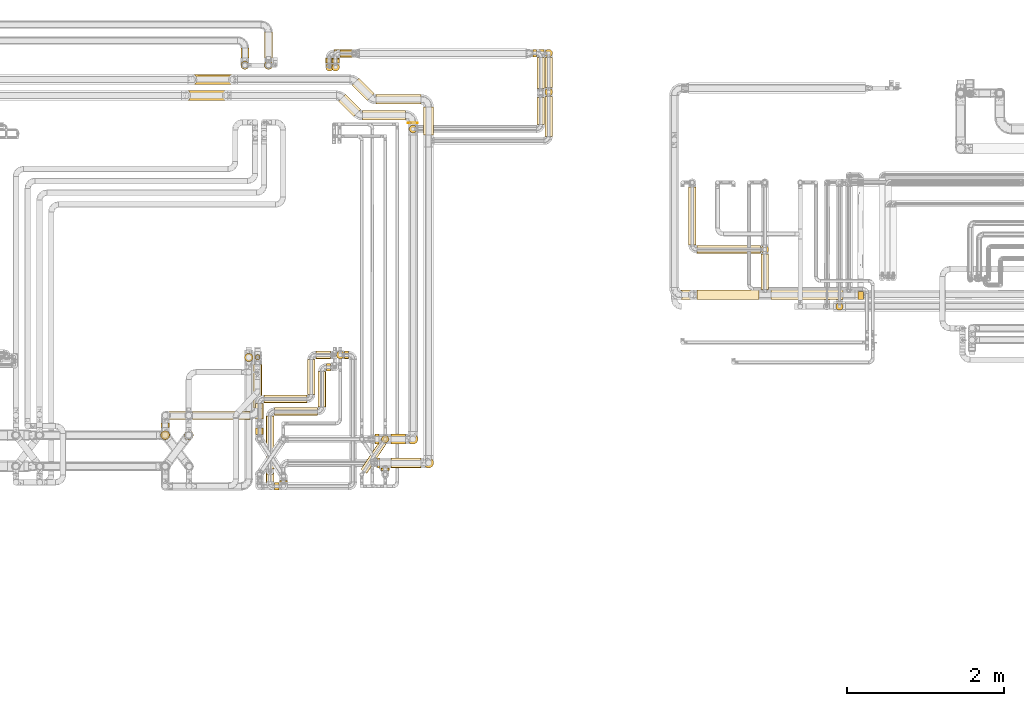
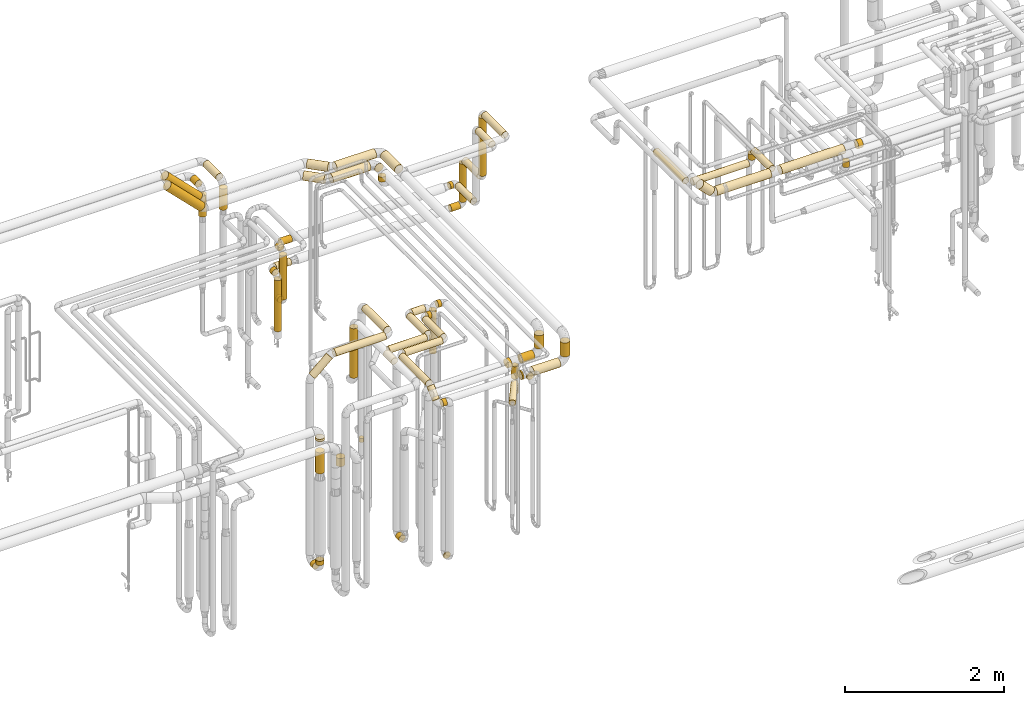
# One storey, part 16 of 824: 71 coverings.
"""IFC2X3 building model written with IfcOpenShell, lengths in millimetres."""

from ifc_helpers import new_model, entity, si_unit, converted_unit, derived_unit, direction, frame, frame_2d, origin, origin_2d_with_axis, place, context, subcontext, project, spatial, polyline, circle_curve, parameter, trimmed, segment, composite_curve, circle, outline, extrude, element, save


model = new_model("IFC2X3")

# Units and contexts
model_context = context("Model", 3, precision=0.01, world=origin(), true_north=direction((6.12303176911189e-17, 1.0)))
body_context = subcontext(model_context, "Body", "Model", "MODEL_VIEW")
ifc_project = project(units=[si_unit("LENGTHUNIT", "METRE", prefix="MILLI"), si_unit("AREAUNIT", "SQUARE_METRE"), si_unit("VOLUMEUNIT", "CUBIC_METRE"), converted_unit("PLANEANGLEUNIT", "DEGREE", entity("IfcRatioMeasure", 0.0174532925199433), si_unit("PLANEANGLEUNIT", "RADIAN"), dimensions=[0, 0, 0, 0, 0, 0, 0]), si_unit("MASSUNIT", "GRAM", prefix="KILO"), derived_unit("MASSDENSITYUNIT", [(si_unit("MASSUNIT", "GRAM", prefix="KILO"), 1), (si_unit("LENGTHUNIT", "METRE"), -3)]), derived_unit("MOMENTOFINERTIAUNIT", [(si_unit("LENGTHUNIT", "METRE"), 4)]), si_unit("TIMEUNIT", "SECOND"), si_unit("FREQUENCYUNIT", "HERTZ"), si_unit("THERMODYNAMICTEMPERATUREUNIT", "DEGREE_CELSIUS"), derived_unit("THERMALTRANSMITTANCEUNIT", [(si_unit("MASSUNIT", "GRAM", prefix="KILO"), 1), (si_unit("THERMODYNAMICTEMPERATUREUNIT", "KELVIN"), -1), (si_unit("TIMEUNIT", "SECOND"), -3)]), derived_unit("VOLUMETRICFLOWRATEUNIT", [(si_unit("LENGTHUNIT", "METRE"), 3), (si_unit("TIMEUNIT", "SECOND"), -1)]), derived_unit("MASSFLOWRATEUNIT", [(si_unit("MASSUNIT", "GRAM", prefix="KILO"), 1), (si_unit("TIMEUNIT", "SECOND"), -1)]), derived_unit("ROTATIONALFREQUENCYUNIT", [(si_unit("TIMEUNIT", "SECOND"), -1)]), si_unit("ELECTRICCURRENTUNIT", "AMPERE"), si_unit("ELECTRICVOLTAGEUNIT", "VOLT"), si_unit("POWERUNIT", "WATT"), si_unit("FORCEUNIT", "NEWTON", prefix="KILO"), si_unit("ILLUMINANCEUNIT", "LUX"), si_unit("LUMINOUSFLUXUNIT", "LUMEN"), si_unit("LUMINOUSINTENSITYUNIT", "CANDELA"), derived_unit("USERDEFINED", [(si_unit("MASSUNIT", "GRAM", prefix="KILO"), -1), (si_unit("LENGTHUNIT", "METRE"), -2), (si_unit("TIMEUNIT", "SECOND"), 3), (si_unit("LUMINOUSFLUXUNIT", "LUMEN"), 1)]), derived_unit("LINEARVELOCITYUNIT", [(si_unit("LENGTHUNIT", "METRE"), 1), (si_unit("TIMEUNIT", "SECOND"), -1)]), si_unit("PRESSUREUNIT", "PASCAL"), derived_unit("USERDEFINED", [(si_unit("LENGTHUNIT", "METRE"), -2), (si_unit("MASSUNIT", "GRAM", prefix="KILO"), 1), (si_unit("TIMEUNIT", "SECOND"), -2)]), derived_unit("LINEARFORCEUNIT", [(si_unit("MASSUNIT", "GRAM", prefix="KILO"), 1), (si_unit("LENGTHUNIT", "METRE"), 1), (si_unit("TIMEUNIT", "SECOND"), -2), (si_unit("LENGTHUNIT", "METRE"), -1)]), derived_unit("PLANARFORCEUNIT", [(si_unit("MASSUNIT", "GRAM", prefix="KILO"), 1), (si_unit("LENGTHUNIT", "METRE"), 1), (si_unit("TIMEUNIT", "SECOND"), -2), (si_unit("LENGTHUNIT", "METRE"), -2)])], contexts=[model_context])

# Site, building, storey
site_placement = place(None, origin())
site = spatial("IfcSite", under=ifc_project, at=site_placement, CompositionType="ELEMENT")
building_placement = place(site_placement, origin())
building = spatial("IfcBuilding", under=site, at=building_placement, CompositionType="ELEMENT")
storey_placement = place(building_placement, frame((0.0, 0.0, 28200.0)))
storey = spatial("IfcBuildingStorey", under=building, at=storey_placement, CompositionType="ELEMENT", Elevation=28200.0)

# Coverings
covering_1_placement = place(storey_placement, frame((48174.38, 18494.16, 2935.65)))
element("IfcCovering", 1, at=covering_1_placement, inside=storey, PredefinedType="INSULATION", context=body_context, shape_type="SweptSolid", body=[
    extrude(circle(Radius=62.75, at=origin_2d_with_axis()), frame((0.0, 64.35, 64.35), z_axis=(1.0, 0.0, 0.0), x_axis=(0.0, -1.0, 0.0)), (0.0, 0.0, 1.0), 575.649711574558),
])
covering_2_placement = place(storey_placement, frame((47865.57, 18540.36, 2935.65)))
element("IfcCovering", 2, at=covering_2_placement, inside=storey, PredefinedType="INSULATION", context=body_context, shape_type="SweptSolid", body=[
    extrude(circle(Radius=62.75, at=origin_2d_with_axis()), frame((45.97, 241.63, 64.35), z_axis=(0.707106781186485, -0.70710678118661, 0.0), x_axis=(-0.70710678118661, -0.707106781186485, 0.0)), (0.0, 0.0, 1.0), 276.715492530282),
])
covering_3_placement = place(storey_placement, frame((48780.69, 18106.53, 2935.65)))
element("IfcCovering", 3, at=covering_3_placement, inside=storey, PredefinedType="INSULATION", context=body_context, shape_type="SweptSolid", body=[
    extrude(circle(Radius=62.75, at=origin_2d_with_axis()), frame((64.35, 0.0, 64.35), z_axis=(0.0, 1.0, 0.0), x_axis=(1.0, 0.0, 0.0)), (0.0, 0.0, 1.0), 356.978263748389),
])
covering_4_placement = place(storey_placement, frame((45805.68, 18744.58, 2981.86)))
element("IfcCovering", 4, at=covering_4_placement, inside=storey, PredefinedType="INSULATION", context=body_context, shape_type="SweptSolid", body=[
    extrude(circle(Radius=62.75, at=origin_2d_with_axis()), frame((45.97, 64.35, 540.32), z_axis=(0.70710619769924, 0.00128465974007588, -0.70710619769924), x_axis=(0.000908391613723806, -0.999999174824336, -0.000908391613726204)), (0.0, 0.0, 1.0), 699.117459348992),
])
covering_5_placement = place(storey_placement, frame((48780.69, 13869.16, 2692.43)))
element("IfcCovering", 5, at=covering_5_placement, inside=storey, PredefinedType="INSULATION", context=body_context, shape_type="SweptSolid", body=[
    extrude(circle(Radius=62.75, at=origin_2d_with_axis()), frame((64.35, 64.35, 0.0), z_axis=(0.0, 0.0, 1.0), x_axis=(0.0, 1.0, 0.0)), (0.0, 0.0, 1.0), 212.567197891267),
])
covering_6_placement = place(storey_placement, frame((48195.03, 13869.16, 2533.15)))
element("IfcCovering", 6, at=covering_6_placement, inside=storey, PredefinedType="INSULATION", context=body_context, shape_type="SweptSolid", body=[
    extrude(circle(Radius=62.75, at=origin_2d_with_axis()), frame((0.0, 64.35, 64.35), z_axis=(1.0, 0.0, 0.0), x_axis=(0.0, -1.0, 0.0)), (0.0, 0.0, 1.0), 20.9896740925879),
])
covering_7_placement = place(storey_placement, frame((48241.43, 13843.1, 2546.9)))
element("IfcCovering", 7, at=covering_7_placement, inside=storey, PredefinedType="INSULATION", context=body_context, shape_type="SweptSolid", body=[
    extrude(circle(Radius=49.0, at=origin_2d_with_axis()), frame((50.6, 0.0, 50.6), z_axis=(0.0, 1.0, 0.0), x_axis=(-1.0, 0.0, 0.0)), (0.0, 0.0, 1.0), 23.4071590179462),
])
covering_8_placement = place(storey_placement, frame((48368.02, 13869.16, 2533.15)))
element("IfcCovering", 8, at=covering_8_placement, inside=storey, PredefinedType="INSULATION", context=body_context, shape_type="SweptSolid", body=[
    extrude(circle(Radius=62.75, at=origin_2d_with_axis()), frame((0.0, 64.35, 64.35), z_axis=(1.0, 0.0, 0.0), x_axis=(0.0, -1.0, 0.0)), (0.0, 0.0, 1.0), 382.010325907433),
])
covering_9_placement = place(storey_placement, frame((51989.91, 16008.03, 2681.53)))
element("IfcCovering", 9, at=covering_9_placement, inside=storey, PredefinedType="INSULATION", context=body_context, shape_type="SweptSolid", body=[
    extrude(circle(Radius=62.75, at=origin_2d_with_axis()), frame((202.15, 64.35, 46.1), z_axis=(-0.709187265322835, 0.0, 0.705020157657863), x_axis=(0.0, 1.0, 0.0)), (0.0, 0.0, 1.0), 220.413379022299),
])
covering_10_placement = place(storey_placement, frame((53070.46, 16139.31, 2648.82)))
element("IfcCovering", 10, at=covering_10_placement, inside=storey, PredefinedType="INSULATION", context=body_context, shape_type="SweptSolid", body=[
    extrude(circle(Radius=49.0, at=origin_2d_with_axis()), frame((50.6, 452.08, 50.6), z_axis=(0.0, -0.999999057686603, 0.00137281677840633), x_axis=(1.0, 0.0, 0.0)), (0.0, 0.0, 1.0), 452.00943964707),
])
covering_11_placement = place(storey_placement, frame((52259.0, 16008.03, 2635.69)))
element("IfcCovering", 11, at=covering_11_placement, inside=storey, PredefinedType="INSULATION", context=body_context, shape_type="SweptSolid", body=[
    extrude(circle(Radius=62.75, at=origin_2d_with_axis()), frame((0.0, 64.35, 64.35), z_axis=(1.0, 0.0, 0.0), x_axis=(0.0, 1.0, 0.0)), (0.0, 0.0, 1.0), 786.054556925048),
])
covering_12_placement = place(storey_placement, frame((52147.68, 16705.39, 2447.57)))
element("IfcCovering", 12, at=covering_12_placement, inside=storey, PredefinedType="INSULATION", context=body_context, shape_type="SweptSolid", body=[
    extrude(circle(Radius=49.0, at=origin_2d_with_axis()), frame((50.6, 0.0, 50.6), z_axis=(0.0, 1.0, 0.0), x_axis=(1.0, 0.0, 0.0)), (0.0, 0.0, 1.0), 737.613736356019),
])
covering_13_placement = place(storey_placement, frame((52255.28, 16597.79, 2447.57)))
element("IfcCovering", 13, at=covering_13_placement, inside=storey, PredefinedType="INSULATION", context=body_context, shape_type="SweptSolid", body=[
    extrude(circle(Radius=49.0, at=origin_2d_with_axis()), frame((0.0, 50.6, 50.6), z_axis=(1.0, 0.0, 0.0), x_axis=(0.0, 1.0, 0.0)), (0.0, 0.0, 1.0), 808.780981573714),
])
covering_14_placement = place(storey_placement, frame((53070.46, 16597.71, 2555.14)))
element("IfcCovering", 14, at=covering_14_placement, inside=storey, PredefinedType="INSULATION", context=body_context, shape_type="SweptSolid", body=[
    extrude(circle(Radius=49.0, at=origin_2d_with_axis()), frame((50.6, 50.64, 0.03), z_axis=(0.0, -0.000542908855839149, 0.999999852624976), x_axis=(0.0, -0.999999852624976, -0.000542908855839149)), (0.0, 0.0, 1.0), 87.1320315967125),
])
covering_15_placement = place(storey_placement, frame((53197.06, 16008.03, 2635.69)))
element("IfcCovering", 15, at=covering_15_placement, inside=storey, PredefinedType="INSULATION", context=body_context, shape_type="SweptSolid", body=[
    extrude(circle(Radius=62.75, at=origin_2d_with_axis()), frame((0.0, 64.35, 64.35), z_axis=(1.0, 0.0, 0.0), x_axis=(0.0, 1.0, 0.0)), (0.0, 0.0, 1.0), 916.731510000015),
])
covering_16_placement = place(storey_placement, frame((48004.19, 18291.33, 2935.65)))
element("IfcCovering", 16, at=covering_16_placement, inside=storey, PredefinedType="INSULATION", context=body_context, shape_type="SweptSolid", body=[
    extrude(circle(Radius=62.75, at=origin_2d_with_axis()), frame((0.0, 64.35, 64.35), z_axis=(1.0, 0.0, 0.0), x_axis=(0.0, -1.0, 0.0)), (0.0, 0.0, 1.0), 545.649711574547),
])
covering_17_placement = place(storey_placement, frame((47695.68, 18337.54, 2935.65)))
element("IfcCovering", 17, at=covering_17_placement, inside=storey, PredefinedType="INSULATION", context=body_context, shape_type="SweptSolid", body=[
    extrude(circle(Radius=62.75, at=origin_2d_with_axis()), frame((45.97, 241.34, 64.35), z_axis=(0.707106781186555, -0.70710678118654, 0.0), x_axis=(-0.70710678118654, -0.707106781186555, 0.0)), (0.0, 0.0, 1.0), 276.299423149123),
])
covering_18_placement = place(storey_placement, frame((48580.5, 18256.53, 2935.65)))
element("IfcCovering", 18, at=covering_18_placement, inside=storey, PredefinedType="INSULATION", context=body_context, shape_type="SweptSolid", body=[
    extrude(circle(Radius=62.75, at=origin_2d_with_axis()), frame((64.35, 0.0, 64.35), z_axis=(0.0, 1.0, 0.0), x_axis=(1.0, 0.0, 0.0)), (0.0, 0.0, 1.0), 4.1498271651662),
])
covering_19_placement = place(storey_placement, frame((45725.68, 18542.35, 2981.86)))
element("IfcCovering", 19, at=covering_19_placement, inside=storey, PredefinedType="INSULATION", context=body_context, shape_type="SweptSolid", body=[
    extrude(circle(Radius=62.75, at=origin_2d_with_axis()), frame((45.97, 64.35, 540.32), z_axis=(0.707106781186548, 0.0, -0.707106781186548), x_axis=(0.0, -1.0, 0.0)), (0.0, 0.0, 1.0), 699.116571318315),
])
covering_20_placement = place(storey_placement, frame((48580.5, 14171.33, 2700.0)))
element("IfcCovering", 20, at=covering_20_placement, inside=storey, PredefinedType="INSULATION", context=body_context, shape_type="SweptSolid", body=[
    extrude(circle(Radius=62.75, at=origin_2d_with_axis()), frame((64.35, 64.35, 0.0), z_axis=(0.0, 0.0, 1.0), x_axis=(-1.0, 0.0, 0.0)), (0.0, 0.0, 1.0), 205.000000000018),
])
covering_21_placement = place(storey_placement, frame((48164.84, 14171.33, 2540.65)))
element("IfcCovering", 21, at=covering_21_placement, inside=storey, PredefinedType="INSULATION", context=body_context, shape_type="SweptSolid", body=[
    extrude(circle(Radius=62.75, at=origin_2d_with_axis()), frame((0.0, 64.35, 64.35), z_axis=(1.0, 0.0, 0.0), x_axis=(0.0, -1.0, 0.0)), (0.0, 0.0, 1.0), 51.1810195864036),
])
covering_22_placement = place(storey_placement, frame((48244.28, 14187.93, 2117.5)))
element("IfcCovering", 22, at=covering_22_placement, inside=storey, PredefinedType="INSULATION", context=body_context, shape_type="SweptSolid", body=[
    extrude(circle(Radius=46.15, at=origin_2d_with_axis()), frame((47.75, 47.75, 0.0), z_axis=(0.0, 0.0, 1.0), x_axis=(0.0, 1.0, 0.0)), (0.0, 0.0, 1.0), 134.500000000013),
])
covering_23_placement = place(storey_placement, frame((48368.02, 14171.33, 2540.65)))
element("IfcCovering", 23, at=covering_23_placement, inside=storey, PredefinedType="INSULATION", context=body_context, shape_type="SweptSolid", body=[
    extrude(circle(Radius=62.75, at=origin_2d_with_axis()), frame((0.0, 64.35, 64.35), z_axis=(1.0, 0.0, 0.0), x_axis=(0.0, -1.0, 0.0)), (0.0, 0.0, 1.0), 181.818980413621),
])
covering_24_placement = place(storey_placement, frame((47980.98, 13799.35, 2252.25)))
element("IfcCovering", 24, at=covering_24_placement, inside=storey, PredefinedType="INSULATION", context=body_context, shape_type="SweptSolid", body=[
    extrude(circle(Radius=46.15, at=origin_2d_with_axis()), frame((40.1, 27.03, 47.75), z_axis=(0.551214458685239, 0.834363602116211, 0.0), x_axis=(-0.834363602116211, 0.551214458685239, 0.0)), (0.0, 0.0, 1.0), 442.846744306639),
])
covering_25_placement = place(storey_placement, frame((48244.28, 14187.93, 2348.0)))
element("IfcCovering", 25, at=covering_25_placement, inside=storey, PredefinedType="INSULATION", context=body_context, shape_type="SweptSolid", body=[
    extrude(circle(Radius=46.15, at=origin_2d_with_axis()), frame((47.75, 47.75, 0.0), z_axis=(0.0, 0.0, 1.0), x_axis=(0.0, 1.0, 0.0)), (0.0, 0.0, 1.0), 192.999999999991),
])
covering_26_placement = place(storey_placement, frame((46453.47, 19086.22, 2945.65)))
element("IfcCovering", 26, at=covering_26_placement, inside=storey, PredefinedType="INSULATION", context=body_context, shape_type="SweptSolid", body=[
    extrude(circle(Radius=52.75, at=origin_2d_with_axis()), frame((54.35, 0.0, 54.35), z_axis=(0.0, 1.0, 0.0), x_axis=(1.0, 0.0, 0.0)), (0.0, 0.0, 1.0), 126.011600000002),
])
covering_27_placement = place(storey_placement, frame((46453.47, 18936.88, 2580.0)))
element("IfcCovering", 27, at=covering_27_placement, inside=storey, PredefinedType="INSULATION", context=body_context, shape_type="SweptSolid", body=[
    extrude(circle(Radius=52.75, at=origin_2d_with_axis()), frame((54.35, 54.35, 0.0), z_axis=(0.0, 0.0, 1.0), x_axis=(-1.0, 0.0, 0.0)), (0.0, 0.0, 1.0), 325.000000000008),
])
covering_28_placement = place(storey_placement, frame((54022.04, 15874.63, 2548.0)))
element("IfcCovering", 28, at=covering_28_placement, inside=storey, PredefinedType="INSULATION", context=body_context, shape_type="SweptSolid", body=[
    extrude(circle(Radius=46.15, at=origin_2d_with_axis()), frame((47.75, 47.75, 0.0), z_axis=(0.0, 0.0, 1.0), x_axis=(-1.0, 0.0, 0.0)), (0.0, 0.0, 1.0), 87.999999999941),
])
covering_29_placement = place(storey_placement, frame((47301.4, 14804.03, 2949.4)))
element("IfcCovering", 29, at=covering_29_placement, inside=storey, PredefinedType="INSULATION", context=body_context, shape_type="SweptSolid", body=[
    extrude(circle(Radius=49.0, at=origin_2d_with_axis()), frame((50.6, 0.0, 50.6), z_axis=(0.0, 1.0, 0.0), x_axis=(1.0, 0.0, 0.0)), (0.0, 0.0, 1.0), 446.000000000016),
])
covering_30_placement = place(storey_placement, frame((46642.19, 14296.53, 349.4)))
element("IfcCovering", 30, at=covering_30_placement, inside=storey, PredefinedType="INSULATION", context=body_context, shape_type="SweptSolid", body=[
    extrude(circle(Radius=49.0, at=origin_2d_with_axis()), frame((50.6, 0.0, 50.6), z_axis=(0.0, 1.0, 0.0), x_axis=(1.0, 0.0, 0.0)), (0.0, 0.0, 1.0), 81.0000000000119),
])
covering_31_placement = place(storey_placement, frame((47409.0, 15256.43, 2949.4)))
element("IfcCovering", 31, at=covering_31_placement, inside=storey, PredefinedType="INSULATION", context=body_context, shape_type="SweptSolid", body=[
    extrude(circle(Radius=49.0, at=origin_2d_with_axis()), frame((0.0, 50.6, 50.6), z_axis=(1.0, 0.0, 0.0), x_axis=(0.0, 1.0, 0.0)), (0.0, 0.0, 1.0), 186.00000000001),
])
covering_32_placement = place(storey_placement, frame((46749.79, 14696.43, 2949.4)))
element("IfcCovering", 32, at=covering_32_placement, inside=storey, PredefinedType="INSULATION", context=body_context, shape_type="SweptSolid", body=[
    extrude(circle(Radius=49.0, at=origin_2d_with_axis()), frame((0.0, 50.6, 50.6), z_axis=(1.0, 0.0, 0.0), x_axis=(0.0, -1.0, 0.0)), (0.0, 0.0, 1.0), 545.208916433662),
])
covering_33_placement = place(storey_placement, frame((46642.19, 14491.53, 2949.4)))
element("IfcCovering", 33, at=covering_33_placement, inside=storey, PredefinedType="INSULATION", context=body_context, shape_type="SweptSolid", body=[
    extrude(circle(Radius=49.0, at=origin_2d_with_axis()), frame((50.6, 0.0, 50.6), z_axis=(0.0, 1.0, 0.0), x_axis=(-1.0, 0.0, 0.0)), (0.0, 0.0, 1.0), 198.500000000011),
])
covering_34_placement = place(storey_placement, frame((47777.26, 15256.43, 2949.4)))
element("IfcCovering", 34, at=covering_34_placement, inside=storey, PredefinedType="INSULATION", context=body_context, shape_type="SweptSolid", body=[
    extrude(circle(Radius=49.0, at=origin_2d_with_axis()), frame((0.0, 50.6, 50.6), z_axis=(1.0, 0.0, 0.0), x_axis=(0.0, -1.0, 0.0)), (0.0, 0.0, 1.0), 49.749999999993),
])
covering_35_placement = place(storey_placement, frame((47669.42, 15256.43, 2287.62)))
element("IfcCovering", 35, at=covering_35_placement, inside=storey, PredefinedType="INSULATION", context=body_context, shape_type="SweptSolid", body=[
    extrude(circle(Radius=49.0, at=origin_2d_with_axis()), frame((50.6, 50.6, 0.0), z_axis=(0.0, 0.0, 1.0), x_axis=(-1.0, 0.0, 0.0)), (0.0, 0.0, 1.0), 655.375000000061),
])
covering_36_placement = place(storey_placement, frame((47437.4, 14645.75, 2949.4)))
element("IfcCovering", 36, at=covering_36_placement, inside=storey, PredefinedType="INSULATION", context=body_context, shape_type="SweptSolid", body=[
    extrude(circle(Radius=49.0, at=origin_2d_with_axis()), frame((50.6, 0.0, 50.6), z_axis=(0.0, 1.0, 0.0), x_axis=(1.0, 0.0, 0.0)), (0.0, 0.0, 1.0), 448.489185095073),
])
covering_37_placement = place(storey_placement, frame((46947.93, 13694.22, 349.4)))
element("IfcCovering", 37, at=covering_37_placement, inside=storey, PredefinedType="INSULATION", context=body_context, shape_type="SweptSolid", body=[
    extrude(circle(Radius=49.0, at=origin_2d_with_axis()), frame((50.6, 0.0, 50.6), z_axis=(0.0, 1.0, 0.0), x_axis=(-1.0, 0.0, 0.0)), (0.0, 0.0, 1.0), 12.5440336639325),
])
covering_38_placement = place(storey_placement, frame((47545.0, 15100.64, 2949.4)))
element("IfcCovering", 38, at=covering_38_placement, inside=storey, PredefinedType="INSULATION", context=body_context, shape_type="SweptSolid", body=[
    extrude(circle(Radius=49.0, at=origin_2d_with_axis()), frame((0.0, 50.6, 50.6), z_axis=(1.0, 0.0, 0.0), x_axis=(0.0, 1.0, 0.0)), (0.0, 0.0, 1.0), 49.749999999993),
])
covering_39_placement = place(storey_placement, frame((46885.0, 13586.24, 2759.19)))
element("IfcCovering", 39, at=covering_39_placement, inside=storey, PredefinedType="INSULATION", context=body_context, shape_type="SweptSolid", body=[
    extrude(circle(Radius=49.0, at=origin_2d_with_axis()), frame((0.0, 50.6, 50.6), z_axis=(1.0, -2.35333717118907e-08, 0.0), x_axis=(-2.35333717118907e-08, -1.0, 0.0)), (0.0, 0.0, 1.0), 56.5308175749362),
])
covering_40_placement = place(storey_placement, frame((46885.0, 14538.15, 2949.4)))
element("IfcCovering", 40, at=covering_40_placement, inside=storey, PredefinedType="INSULATION", context=body_context, shape_type="SweptSolid", body=[
    extrude(circle(Radius=49.0, at=origin_2d_with_axis()), frame((0.0, 50.6, 50.6), z_axis=(1.0, 0.0, 0.0), x_axis=(0.0, -1.0, 0.0)), (0.0, 0.0, 1.0), 546.000000000006),
])
covering_41_placement = place(storey_placement, frame((46777.4, 13856.65, 2949.4)))
element("IfcCovering", 41, at=covering_41_placement, inside=storey, PredefinedType="INSULATION", context=body_context, shape_type="SweptSolid", body=[
    extrude(circle(Radius=49.0, at=origin_2d_with_axis()), frame((50.6, 0.0, 50.6), z_axis=(0.0, 1.0, 0.0), x_axis=(1.0, 0.0, 0.0)), (0.0, 0.0, 1.0), 675.09993070178),
])
covering_42_placement = place(storey_placement, frame((46777.4, 13642.17, 2812.58)))
element("IfcCovering", 42, at=covering_42_placement, inside=storey, PredefinedType="INSULATION", context=body_context, shape_type="SweptSolid", body=[
    extrude(circle(Radius=49.0, at=origin_2d_with_axis()), frame((50.6, 35.65, 36.82), z_axis=(0.0, 0.718969901615608, 0.695041207822128), x_axis=(-1.0, 0.0, 0.0)), (0.0, 0.0, 1.0), 193.624123419369),
])
covering_43_placement = place(storey_placement, frame((50221.44, 18237.53, 2749.4)))
element("IfcCovering", 43, at=covering_43_placement, inside=storey, PredefinedType="INSULATION", context=body_context, shape_type="SweptSolid", body=[
    extrude(circle(Radius=49.0, at=origin_2d_with_axis()), frame((50.6, 0.0, 50.6), z_axis=(0.0, 1.0, 0.0), x_axis=(-1.0, 0.0, 0.0)), (0.0, 0.0, 1.0), 345.999999999954),
])
covering_44_placement = place(storey_placement, frame((48594.25, 18129.93, 2857.0)))
element("IfcCovering", 44, at=covering_44_placement, inside=storey, PredefinedType="INSULATION", context=body_context, shape_type="SweptSolid", body=[
    extrude(circle(Radius=49.0, at=origin_2d_with_axis()), frame((50.6, 50.6, 0.0)), (0.0, 0.0, 1.0), 75.9999999999611),
])
covering_45_placement = place(storey_placement, frame((50221.44, 18697.53, 1599.4)))
element("IfcCovering", 45, at=covering_45_placement, inside=storey, PredefinedType="INSULATION", context=body_context, shape_type="SweptSolid", body=[
    extrude(circle(Radius=49.0, at=origin_2d_with_axis()), frame((50.6, 0.0, 50.6), z_axis=(0.0, 1.0, 0.0), x_axis=(-1.0, 0.0, 0.0)), (0.0, 0.0, 1.0), 390.99999997821),
])
covering_46_placement = place(storey_placement, frame((50172.3, 19094.93, 1599.4)))
element("IfcCovering", 46, at=covering_46_placement, inside=storey, PredefinedType="INSULATION", context=body_context, shape_type="SweptSolid", body=[
    extrude(circle(Radius=49.0, at=origin_2d_with_axis()), frame((0.0, 50.6, 50.6), z_axis=(1.0, 0.0, 0.0), x_axis=(0.0, -1.0, 0.0)), (0.0, 0.0, 1.0), 42.7379771478646),
])
covering_47_placement = place(storey_placement, frame((47718.17, 19090.63, 1599.4)))
element("IfcCovering", 47, at=covering_47_placement, inside=storey, PredefinedType="INSULATION", context=body_context, shape_type="SweptSolid", body=[
    extrude(circle(Radius=49.0, at=origin_2d_with_axis()), frame((0.0, 50.6, 50.6), z_axis=(1.0, 0.0, 0.0), x_axis=(0.0, -1.0, 0.0)), (0.0, 0.0, 1.0), 156.125000000036),
])
covering_48_placement = place(storey_placement, frame((47610.58, 19023.22, 1599.4)))
element("IfcCovering", 48, at=covering_48_placement, inside=storey, PredefinedType="INSULATION", context=body_context, shape_type="SweptSolid", body=[
    extrude(circle(Radius=49.0, at=origin_2d_with_axis()), frame((50.6, 0.0, 50.6), z_axis=(0.0, 1.0, 0.0), x_axis=(1.0, 0.0, 0.0)), (0.0, 0.0, 1.0), 61.0000000000208),
])
covering_49_placement = place(storey_placement, frame((47610.58, 18915.63, 918.88)))
element("IfcCovering", 49, at=covering_49_placement, inside=storey, PredefinedType="INSULATION", context=body_context, shape_type="SweptSolid", body=[
    extrude(circle(Radius=49.0, at=origin_2d_with_axis()), frame((50.6, 50.6, 0.0), z_axis=(0.0, 0.0, 1.0), x_axis=(-1.0, 0.0, 0.0)), (0.0, 0.0, 1.0), 674.12499999997),
])
covering_50_placement = place(storey_placement, frame((47610.58, 19023.22, 811.28)))
element("IfcCovering", 50, at=covering_50_placement, inside=storey, PredefinedType="INSULATION", context=body_context, shape_type="SweptSolid", body=[
    extrude(circle(Radius=49.0, at=origin_2d_with_axis()), frame((50.6, 0.0, 50.6), z_axis=(0.0, 1.0, 0.0), x_axis=(-1.0, 0.0, 0.0)), (0.0, 0.0, 1.0), 48.0000000000086),
])
covering_51_placement = place(storey_placement, frame((50321.44, 18087.53, 2949.4)))
element("IfcCovering", 51, at=covering_51_placement, inside=storey, PredefinedType="INSULATION", context=body_context, shape_type="SweptSolid", body=[
    extrude(circle(Radius=49.0, at=origin_2d_with_axis()), frame((50.6, 0.0, 50.6), z_axis=(0.0, 1.0, 0.0), x_axis=(-1.0, 0.0, 0.0)), (0.0, 0.0, 1.0), 506.000000000015),
])
covering_52_placement = place(storey_placement, frame((50321.44, 18599.93, 2057.0)))
element("IfcCovering", 52, at=covering_52_placement, inside=storey, PredefinedType="INSULATION", context=body_context, shape_type="SweptSolid", body=[
    extrude(circle(Radius=49.0, at=origin_2d_with_axis()), frame((50.6, 50.6, 0.0), z_axis=(0.0, 0.0, 1.0), x_axis=(-1.0, 0.0, 0.0)), (0.0, 0.0, 1.0), 886.000000000011),
])
covering_53_placement = place(storey_placement, frame((50321.44, 18707.53, 1949.4)))
element("IfcCovering", 53, at=covering_53_placement, inside=storey, PredefinedType="INSULATION", context=body_context, shape_type="SweptSolid", body=[
    extrude(circle(Radius=49.0, at=origin_2d_with_axis()), frame((50.6, 0.0, 50.6), z_axis=(0.0, 1.0, 0.0), x_axis=(-1.0, 0.0, 0.0)), (0.0, 0.0, 1.0), 381.000000000007),
])
covering_54_placement = place(storey_placement, frame((50321.44, 19094.93, 1357.0)))
element("IfcCovering", 54, at=covering_54_placement, inside=storey, PredefinedType="INSULATION", context=body_context, shape_type="SweptSolid", body=[
    extrude(circle(Radius=49.0, at=origin_2d_with_axis()), frame((50.6, 50.6, 0.0), z_axis=(0.0, 0.0, 1.0), x_axis=(-1.0, 0.0, 0.0)), (0.0, 0.0, 1.0), 586.00000000001),
])
covering_55_placement = place(storey_placement, frame((50185.03, 19094.93, 1249.4)))
element("IfcCovering", 55, at=covering_55_placement, inside=storey, PredefinedType="INSULATION", context=body_context, shape_type="SweptSolid", body=[
    extrude(circle(Radius=49.0, at=origin_2d_with_axis()), frame((0.0, 50.6, 50.6), z_axis=(1.0, 0.0, 0.0), x_axis=(0.0, -1.0, 0.0)), (0.0, 0.0, 1.0), 130.000000000005),
])
covering_56_placement = place(storey_placement, frame((47641.3, 19090.63, 1249.4)))
element("IfcCovering", 56, at=covering_56_placement, inside=storey, PredefinedType="INSULATION", context=body_context, shape_type="SweptSolid", body=[
    extrude(circle(Radius=49.0, at=origin_2d_with_axis()), frame((0.0, 50.6, 50.6), z_axis=(1.0, 0.0, 0.0), x_axis=(0.0, -1.0, 0.0)), (0.0, 0.0, 1.0), 220.000000000002),
])
covering_57_placement = place(storey_placement, frame((47533.7, 19023.22, 1249.4)))
element("IfcCovering", 57, at=covering_57_placement, inside=storey, PredefinedType="INSULATION", context=body_context, shape_type="SweptSolid", body=[
    extrude(circle(Radius=49.0, at=origin_2d_with_axis()), frame((50.6, 0.0, 50.6), z_axis=(0.0, 1.0, 0.0), x_axis=(1.0, 0.0, 0.0)), (0.0, 0.0, 1.0), 61.0000000000143),
])
covering_58_placement = place(storey_placement, frame((47533.7, 18915.63, 457.0)))
element("IfcCovering", 58, at=covering_58_placement, inside=storey, PredefinedType="INSULATION", context=body_context, shape_type="SweptSolid", body=[
    extrude(circle(Radius=49.0, at=origin_2d_with_axis()), frame((50.6, 50.6, 0.0)), (0.0, 0.0, 1.0), 785.999999709128),
])
covering_59_placement = place(storey_placement, frame((45439.88, 14381.62, 295.65)))
element("IfcCovering", 59, at=covering_59_placement, inside=storey, PredefinedType="INSULATION", context=body_context, shape_type="SweptSolid", body=[
    extrude(circle(Radius=52.75, at=origin_2d_with_axis()), frame((54.35, 0.0, 54.35), z_axis=(0.0, 1.0, 0.0), x_axis=(1.0, 0.0, 0.0)), (0.0, 0.0, 1.0), 61.4604775254828),
])
covering_60_placement = place(storey_placement, frame((45439.88, 14232.27, 445.0)))
element("IfcCovering", 60, at=covering_60_placement, inside=storey, PredefinedType="INSULATION", context=body_context, shape_type="SweptSolid", body=[
    extrude(circle(Radius=52.75, at=origin_2d_with_axis()), frame((54.35, 54.35, 0.0)), (0.0, 0.0, 1.0), 65.0000000000242),
])
covering_61_placement = place(storey_placement, frame((45841.83, 14483.73, 3345.65)))
element("IfcCovering", 61, at=covering_61_placement, inside=storey, PredefinedType="INSULATION", context=body_context, shape_type="SweptSolid", body=[
    extrude(circle(Radius=52.75, at=origin_2d_with_axis()), frame((0.0, 54.35, 54.35), z_axis=(1.0, 0.0, 0.0), x_axis=(0.0, -1.0, 0.0)), (0.0, 0.0, 1.0), 733.72992241483),
])
covering_62_placement = place(storey_placement, frame((46616.22, 14633.08, 3345.65)))
element("IfcCovering", 62, at=covering_62_placement, inside=storey, PredefinedType="INSULATION", context=body_context, shape_type="SweptSolid", body=[
    extrude(circle(Radius=52.75, at=origin_2d_with_axis()), frame((54.35, 0.0, 54.35), z_axis=(0.0, 1.0, 0.0), x_axis=(-1.0, 0.0, 0.0)), (0.0, 0.0, 1.0), 550.000000000011),
])
covering_63_placement = place(storey_placement, frame((45489.92, 14483.73, 3112.41)))
element("IfcCovering", 63, at=covering_63_placement, inside=storey, PredefinedType="INSULATION", context=body_context, shape_type="SweptSolid", body=[
    extrude(circle(Radius=52.75, at=origin_2d_with_axis()), frame((36.48, 54.35, 41.17), z_axis=(0.750137300458903, 0.0, 0.661282111099514), x_axis=(0.0, 1.0, 0.0)), (0.0, 0.0, 1.0), 336.753261279577),
])
covering_64_placement = place(storey_placement, frame((45433.82, 14226.22, 1854.0)))
element("IfcCovering", 64, at=covering_64_placement, inside=storey, PredefinedType="INSULATION", context=body_context, shape_type="SweptSolid", body=[
    extrude(circle(Radius=59.25, at=origin_2d_with_axis()), frame((60.4, 60.4, 0.0), z_axis=(0.0, 0.0, 1.0), x_axis=(-0.798635510047303, -0.601815023152035, 0.0)), (0.0, 0.0, 1.0), 325.000000000008),
])
covering_65_placement = place(storey_placement, frame((46636.47, 15243.98, 1305.25)))
element("IfcCovering", 65, at=covering_65_placement, inside=storey, PredefinedType="INSULATION", context=body_context, shape_type="SweptSolid", body=[
    extrude(circle(Radius=32.5, at=origin_2d_with_axis()), frame((34.1, 34.1, 0.0), z_axis=(0.0, 0.0, 1.0), x_axis=(0.0, -1.0, 0.0)), (0.0, 0.0, 1.0), 61.0000000000035),
])
covering_66_placement = place(storey_placement, frame((46502.43, 15221.02, 2345.05)))
element("IfcCovering", 66, at=covering_66_placement, inside=storey, PredefinedType="INSULATION", context=body_context, shape_type="SweptSolid", body=[
    extrude(circle(Radius=52.75, at=origin_2d_with_axis()), frame((54.35, 54.35, 0.0)), (0.0, 0.0, 1.0), 760.000000000018),
])
covering_67_placement = place(storey_placement, frame((45732.67, 14226.22, 1860.0)))
element("IfcCovering", 67, at=covering_67_placement, inside=storey, PredefinedType="INSULATION", context=body_context, shape_type="SweptSolid", body=[
    extrude(circle(Radius=59.25, at=origin_2d_with_axis()), frame((60.4, 60.4, 0.0), z_axis=(0.0, 0.0, 1.0), x_axis=(0.798635510047289, -0.601815023152053, 0.0)), (0.0, 0.0, 1.0), 126.000000000019),
])
covering_68_placement = place(storey_placement, frame((46753.22, 19086.22, 2945.4)))
element("IfcCovering", 68, at=covering_68_placement, inside=storey, PredefinedType="INSULATION", context=body_context, shape_type="SweptSolid", body=[
    extrude(circle(Radius=53.0, at=origin_2d_with_axis()), frame((54.6, 0.0, 54.6), z_axis=(0.0, 1.0, 0.0), x_axis=(1.0, 0.0, 0.0)), (0.0, 0.0, 1.0), 326.0116),
])
covering_69_placement = place(storey_placement, frame((46753.22, 18936.63, 2580.0)))
element("IfcCovering", 69, at=covering_69_placement, inside=storey, PredefinedType="INSULATION", context=body_context, shape_type="SweptSolid", body=[
    extrude(circle(Radius=53.0, at=origin_2d_with_axis()), frame((54.6, 54.6, 0.0)), (0.0, 0.0, 1.0), 325.000000000017),
])
covering_70_placement = place(storey_placement, frame((45433.38, 14225.77, 2351.0)))
element("IfcCovering", 70, at=covering_70_placement, inside=storey, PredefinedType="INSULATION", context=body_context, shape_type="SweptSolid", body=[
    extrude(circle(Radius=59.25, at=origin_2d_with_axis()), frame((60.85, 60.85, 0.0), z_axis=(0.0, 0.0, 1.0), x_axis=(0.0, 1.0, 0.0)), (0.0, 0.0, 1.0), 34.9999999999747),
])
covering_71_placement = place(storey_placement, frame((54304.79, 16010.78, 2638.44)))
element("IfcCovering", 71, at=covering_71_placement, inside=storey, PredefinedType="INSULATION", context=body_context, shape_type="SweptSolid", body=[
    extrude(outline(composite_curve([segment(trimmed(circle_curve(frame_2d((14.29, 0.0), x_axis=(1.0, 0.0)), 60.0), [parameter(0.0)], [parameter(90.0)], True, "PARAMETER"), True, "CONTINUOUS"), segment(trimmed(circle_curve(frame_2d((14.29, 0.0), x_axis=(1.0, 0.0)), 60.0), [parameter(90.0000000000003)], [parameter(131.810314895778)], True, "PARAMETER"), True, "CONTINUOUS"), segment(polyline([(-25.71, 44.72), (-25.71, 13.46)]), True, "CONTINUOUS"), segment(polyline([(-25.71, 13.46), (-25.71, -13.46)]), True, "CONTINUOUS"), segment(polyline([(-25.71, -13.46), (-25.71, -44.72)]), True, "CONTINUOUS"), segment(trimmed(circle_curve(frame_2d((14.29, 0.0), x_axis=(1.0, 0.0)), 60.0), [parameter(228.189685104222)], [parameter(270.0)], True, "PARAMETER"), True, "CONTINUOUS"), segment(trimmed(circle_curve(frame_2d((14.29, 0.0), x_axis=(1.0, 0.0)), 60.0), [parameter(270.0)], [parameter(0.0)], True, "PARAMETER"), True, "CONTINUOUS")], self_intersect=False)), frame((0.0, 75.88, 61.6), z_axis=(1.0, 0.0, 0.0), x_axis=(0.0, -1.0, 0.0)), (0.0, 0.0, 1.0), 69.9999999999928),
])

save(model, "model.ifc")
